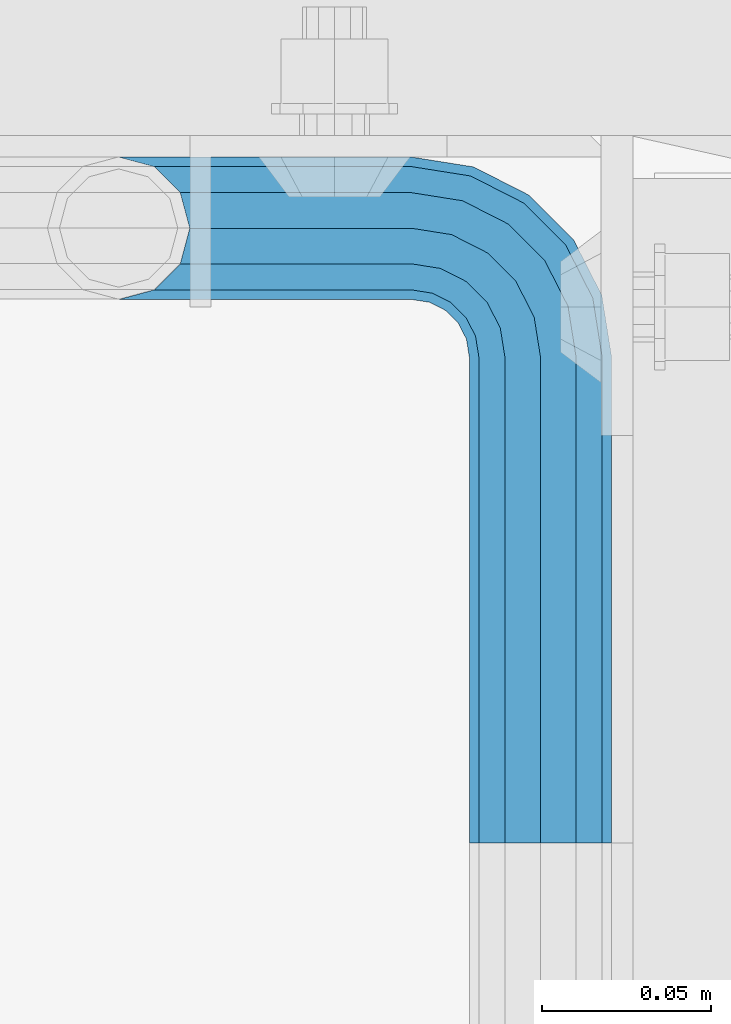
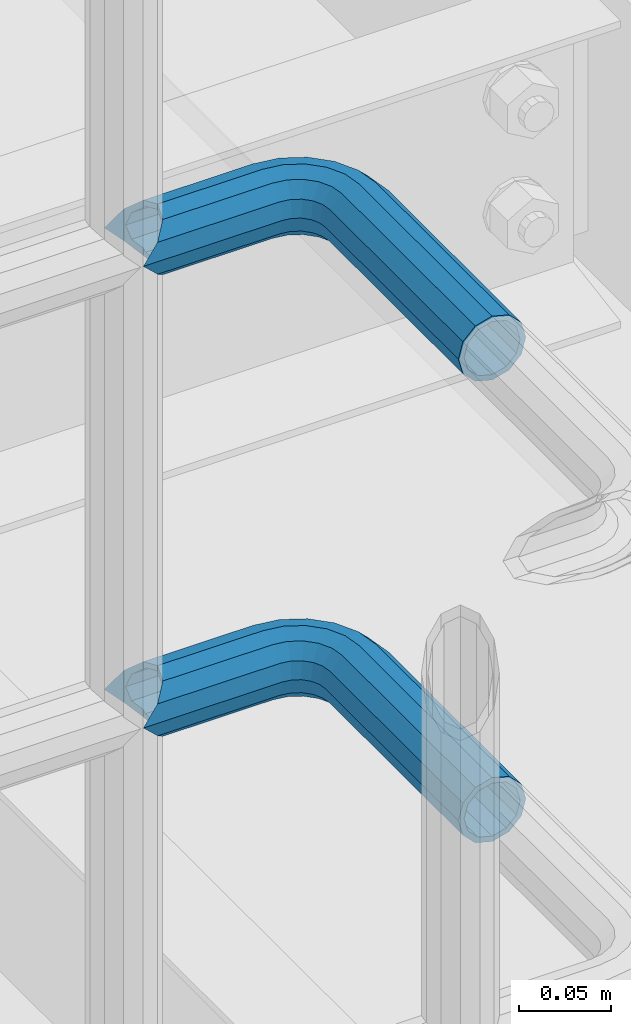
# One storey, part 1112 of 1876: 2 beams, 1 element without a shape of its own.
"""IFC2X3 building model written with IfcOpenShell, lengths in millimetres."""

import ifcopenshell
import ifcopenshell.guid

model = None  # the IFC model being written
_history = None  # IfcOwnerHistory: only IFC2X3 demands one
_inside = {}  # id of a spatial element -> (the spatial element, [elements in it])
_under = {}  # id of a project, library or spatial element -> (it, [spatial elements below it])
_declared = {}  # id of a project -> (the project, [libraries it declares])
_typed = {}  # id of a type object -> (the type object, [elements of that type])
_made_of = {}  # id of a material, layer set ... -> (it, [elements and type objects made of it])


def new_model(schema):
    """Start an empty IFC model of exactly this schema.

    Asked for "IFC4X3", IfcOpenShell would pick the latest addendum, in which some entities
    have other attributes; the version numbers below select the first issue.
    IFC2X3 requires an IfcOwnerHistory on every rooted entity: one is made here for all.
    """
    global model, _history
    if schema == "IFC4X3":
        model = ifcopenshell.file(schema_version=(4, 3, 0, 0))
    else:
        model = ifcopenshell.file(schema=schema)
    _inside.clear()
    _under.clear()
    _declared.clear()
    _typed.clear()
    _made_of.clear()
    _history = None
    if model.schema == "IFC2X3":
        org = make("IfcOrganization", Name="unknown")
        user = make(
            "IfcPersonAndOrganization",
            ThePerson=make("IfcPerson", FamilyName="unknown"),
            TheOrganization=org,
        )
        app = make(
            "IfcApplication",
            ApplicationDeveloper=org,
            Version="unknown",
            ApplicationFullName="unknown",
            ApplicationIdentifier="unknown",
        )
        _history = make(
            "IfcOwnerHistory",
            OwningUser=user,
            OwningApplication=app,
            ChangeAction="ADDED",
            CreationDate=0,
        )
    return model


def make(cls, **values):
    """One entity of the class cls with the attributes given. An attribute that is None is left unset."""
    return model.create_entity(
        cls, **{name: value for name, value in values.items() if value is not None}
    )


def rooted(cls, **values):
    """An entity with a GlobalId (a new one), such as an element, a storey or a relation."""
    return make(cls, GlobalId=ifcopenshell.guid.new(), OwnerHistory=_history, **values)


def si_unit(unit_type, name, prefix=None):
    """IfcSIUnit, for example si_unit("LENGTHUNIT", "METRE", prefix="MILLI")."""
    return make("IfcSIUnit", UnitType=unit_type, Prefix=prefix, Name=name)


def assignment(units):
    """IfcUnitAssignment: the units of a project."""
    return None if units is None else make("IfcUnitAssignment", Units=units)


def point(xyz):
    """IfcCartesianPoint."""
    return None if xyz is None else make("IfcCartesianPoint", Coordinates=xyz)


def direction(xyz):
    """IfcDirection."""
    return None if xyz is None else make("IfcDirection", DirectionRatios=xyz)


def frame(location, z_axis=None, x_axis=None):
    """IfcAxis2Placement3D, a coordinate frame: its origin and axes. An axis left out is left unset."""
    return make(
        "IfcAxis2Placement3D",
        Location=point(location),
        Axis=direction(z_axis),
        RefDirection=direction(x_axis),
    )


def origin_with_axes():
    """The frame at (0, 0, 0) with the z axis (0, 0, 1) and the x axis (1, 0, 0) written out."""
    return frame((0.0, 0.0, 0.0), z_axis=(0.0, 0.0, 1.0), x_axis=(1.0, 0.0, 0.0))


def place(relative_to, where):
    """IfcLocalPlacement: puts the frame where relative to a parent placement (None: the world)."""
    return make(
        "IfcLocalPlacement", PlacementRelTo=relative_to, RelativePlacement=where
    )


def context(
    kind, dimensions, precision=None, world=None, true_north=None, identifier=None
):
    """IfcGeometricRepresentationContext, for example the 3D "Model" context."""
    return make(
        "IfcGeometricRepresentationContext",
        ContextIdentifier=identifier,
        ContextType=kind,
        CoordinateSpaceDimension=dimensions,
        Precision=precision,
        WorldCoordinateSystem=world,
        TrueNorth=true_north,
    )


def subcontext(parent, identifier, kind, view, scale=None):
    """IfcGeometricRepresentationSubContext, for example "Body" below "Model"."""
    return make(
        "IfcGeometricRepresentationSubContext",
        ContextIdentifier=identifier,
        ContextType=kind,
        ParentContext=parent,
        TargetScale=scale,
        TargetView=view,
    )


def project(units=None, contexts=None):
    """IfcProject with its units and contexts."""
    return rooted(
        "IfcProject",
        Name="project",
        RepresentationContexts=contexts,
        UnitsInContext=assignment(units),
    )


def spatial(cls, under=None, at=None, **own):
    """A site, building, storey or space (cls), placed at a placement, below another one or the project."""
    s = rooted(cls, ObjectPlacement=at, **own)
    if under is not None:
        _under.setdefault(under.id(), (under, []))[1].append(s)
    return s


def faces_of(points, faces, orient=None, outer=None):
    """IfcFace entities. A face is a list of loops; a loop is a list of indices into points, from 0.

    orient and outer hold one flag for each loop. By default every Orientation is true, the
    first loop of a face is its IfcFaceOuterBound and the others are IfcFaceBound.
    """
    made = []
    for i, loops in enumerate(faces):
        bounds = []
        for j, loop in enumerate(loops):
            is_outer = j == 0 if outer is None else outer[i][j]
            bounds.append(
                make(
                    "IfcFaceOuterBound" if is_outer else "IfcFaceBound",
                    Bound=make("IfcPolyLoop", Polygon=[points[k] for k in loop]),
                    Orientation=True if orient is None else orient[i][j],
                )
            )
        made.append(make("IfcFace", Bounds=bounds))
    return made


def faceted_brep(points, faces, orient=None, outer=None, voids=None):
    """IfcFacetedBrep: a solid bounded by flat faces; with voids (closed shells), ...WithVoids."""
    shared = [point(p) for p in points]
    hull = make("IfcClosedShell", CfsFaces=faces_of(shared, faces, orient, outer))
    if voids is None:
        return make("IfcFacetedBrep", Outer=hull)
    return make(
        "IfcFacetedBrepWithVoids",
        Outer=hull,
        Voids=[
            make(cls, CfsFaces=faces_of(shared, fs, o, b)) for cls, fs, o, b in voids
        ],
    )


def shape(context_of_items, identifier, shape_type, items):
    """IfcShapeRepresentation: the items that make up one representation, for example the "Body"."""
    return make(
        "IfcShapeRepresentation",
        ContextOfItems=context_of_items,
        RepresentationIdentifier=identifier,
        RepresentationType=shape_type,
        Items=items,
    )


def material(Name=None, Category=None):
    """IfcMaterial."""
    return make("IfcMaterial", Name=Name, Category=Category)


def made_of(thing, what):
    """Note that an element or type object is made of a material, layer set ...; save() writes the relation."""
    if what is not None:
        _made_of.setdefault(what.id(), (what, []))[1].append(thing)
    return thing


def type_object(cls, material=None, **own):
    """A type object (cls), such as IfcWallType, which elements share."""
    return made_of(rooted(cls, **own), material)


def element(
    cls,
    number,
    at=None,
    inside=None,
    cuts=None,
    type_object=None,
    material=None,
    context=None,
    identifier="Body",
    shape_type=None,
    held_by="IfcProductDefinitionShape",
    body=None,
    shapes=None,
    **own,
):
    """One element of the class cls, such as IfcWall. Its Tag is "e" and its number.

    at: its placement. inside: the storey or other place that contains it. cuts: it is an
    opening in that element (IfcRelVoidsElement). A single representation is given by context,
    identifier, shape_type and body (its items); several are given by shapes. held_by: the class
    of the entity that holds the representations. save() writes the other relations.
    """
    e = rooted(cls, Tag="e%d" % number, ObjectPlacement=at, **own)
    if body is not None:
        shapes = [shape(context, identifier, shape_type, body)]
    if shapes is not None:
        e.Representation = make(held_by, Representations=shapes)
    if inside is not None:
        _inside.setdefault(inside.id(), (inside, []))[1].append(e)
    if cuts is not None:
        rooted(
            "IfcRelVoidsElement", RelatingBuildingElement=cuts, RelatedOpeningElement=e
        )
    if type_object is not None:
        _typed.setdefault(type_object.id(), (type_object, []))[1].append(e)
    return made_of(e, material)


def aggregate(whole, parts):
    """IfcRelAggregates: a whole, such as a stair, and the parts it consists of."""
    return rooted("IfcRelAggregates", RelatingObject=whole, RelatedObjects=parts)


def save(model, path):
    """Write the relations noted so far, then the file.

    IfcRelAggregates (storeys below a building ...), IfcRelContainedInSpatialStructure (elements
    in a storey), IfcRelDefinesByType, IfcRelAssociatesMaterial and IfcRelDeclares: one each for
    every whole, place, type object, material and project.
    """
    for whole, parts in _under.values():
        aggregate(whole, parts)
    for where, things in _inside.values():
        rooted(
            "IfcRelContainedInSpatialStructure",
            RelatedElements=things,
            RelatingStructure=where,
        )
    for kind, things in _typed.values():
        rooted("IfcRelDefinesByType", RelatedObjects=things, RelatingType=kind)
    for what, things in _made_of.values():
        rooted("IfcRelAssociatesMaterial", RelatedObjects=things, RelatingMaterial=what)
    for by, libraries in _declared.values():
        rooted("IfcRelDeclares", RelatingContext=by, RelatedDefinitions=libraries)
    model.write(path)


model = new_model("IFC2X3")

# Units and contexts
model_context = context("Model", 3, precision=1e-05, world=origin_with_axes())
body_context = subcontext(model_context, "Body", "Model", "MODEL_VIEW")
ifc_project = project(units=[si_unit("LENGTHUNIT", "METRE", prefix="MILLI"), si_unit("AREAUNIT", "SQUARE_METRE"), si_unit("VOLUMEUNIT", "CUBIC_METRE"), si_unit("MASSUNIT", "GRAM", prefix="KILO"), si_unit("TIMEUNIT", "SECOND"), si_unit("PLANEANGLEUNIT", "RADIAN"), si_unit("SOLIDANGLEUNIT", "STERADIAN"), si_unit("THERMODYNAMICTEMPERATUREUNIT", "DEGREE_CELSIUS"), si_unit("LUMINOUSINTENSITYUNIT", "LUMEN")], contexts=[model_context])

# Site, building, storey
site_placement = place(None, origin_with_axes())
site = spatial("IfcSite", under=ifc_project, at=site_placement, CompositionType="ELEMENT")
building_placement = place(site_placement, origin_with_axes())
building = spatial("IfcBuilding", under=site, at=building_placement, Name="Undefined", CompositionType="ELEMENT")
storey_placement = place(building_placement, origin_with_axes())
storey = spatial("IfcBuildingStorey", under=building, at=storey_placement, Name="Undefined", CompositionType="ELEMENT", Elevation=0.0)

# Assembly, beams
assembly_placement = place(storey_placement, origin_with_axes())
assembly = element("IfcElementAssembly", 1, at=assembly_placement, inside=storey, Name="HANDRAIL", AssemblyPlace="NOTDEFINED", PredefinedType="RIGID_FRAME")
ifc_material = material()
beam_type = type_object("IfcBeamType", Name="PIPE1-1/4STD", PredefinedType="NOTDEFINED")
beam_1_placement = place(assembly_placement, frame((4696.96656849878, -11563.3144042962, 8480.425), z_axis=(0.0, 0.0, -1.0), x_axis=(0.0, 1.0, 0.0)))
beam_1 = element("IfcBeam", 2, at=beam_1_placement, type_object=beam_type, material=ifc_material, Name="HANDRAIL", ObjectType="PIPE1-1/4STD", context=body_context, shape_type="Brep", body=[
    faceted_brep([(160.964844482422, -124.968002319336, 0.0), (163.789296919838, -114.42699926758, -10.5409999999993), (163.789296919838, -114.42699926758, 10.5409999999993), (190.809844482423, -106.234034770496, -15.1779612267255), (182.046844482422, -103.88599926758, -17.5259999999998), (182.046844482422, -103.88599926758, -21.0820000000003), (192.587844482423, -106.710451704997, -18.2575475625836), (192.587856687565, -106.710451704997, -13.3999490215811), (173.283844482423, -106.234041311212, -15.1779612267255), (171.505856687567, -106.710451704997, -13.3999734318695), (171.505844482423, -106.710451704997, -18.2575475625836), (166.868883255696, -111.347425136867, -8.76300000000083), (164.520844482422, -113.69546391014, 0.0), (166.868883255696, -111.347425136867, 8.76300000000083), (171.505856687567, -106.710451704997, 13.3999734318695), (171.505844482423, -106.710451704997, 18.2575475625836), (173.283844482423, -106.234041311212, 15.1779612267255), (182.046844482422, -103.88599926758, 17.5259999999998), (182.046844482422, -103.88599926758, 21.0820000000003), (190.809844482423, -106.234034770496, 15.1779612267255), (192.587856687565, -106.710451704997, 13.3999490215811), (192.587844482423, -106.710451704997, 18.2575475625836), (203.128856687566, -124.96799926758, 0.0), (200.304392045005, -114.42699926758, 10.5409999999993), (200.304392045005, -114.42699926758, -10.5409999999993), (197.224805709147, -111.347400726579, 8.76300000000083), (199.572844482422, -113.695439499853, 0.0), (197.224805709147, -111.347400726579, -8.76300000000083), (0.0, -18.2575475625836, -10.5409999999993), (0.0, -10.5410000000002, -18.2575475625836), (143.946846008301, -10.5410000000011, -18.2575475625836), (143.946846008301, -18.2575475625854, -10.5409999999993), (-4.28826751885936e-09, 0.0, -21.0820000000003), (143.946846008301, -1.81898940354586e-12, -21.0820000000003), (0.0, 10.5410000000002, -18.2575475625836), (143.946846008301, 10.5409999999983, -18.2575475625836), (0.0, 18.2575475625836, -10.5409999999993), (143.946846008301, 18.2575475625817, -10.5409999999993), (9.09494701772928e-13, 21.0820000000003, 0.0), (143.946846008301, 21.0819999999985, 0.0), (0.0, 18.2575475625836, 10.5409999999993), (143.946846008301, 18.2575475625817, 10.5409999999993), (0.0, 10.5410000000002, 18.2575475625836), (143.946846008301, 10.5409999999983, 18.2575475625836), (0.0, 0.0, 21.0820000000003), (143.946846008301, -1.81898940354586e-12, 21.0820000000003), (0.0, -10.5410000000002, 18.2575475625836), (143.946846008301, -10.5410000000011, 18.2575475625836), (0.0, -18.2575475625836, 10.5409999999993), (143.946846008301, -18.2575475625854, 10.5409999999993), (9.09494701772928e-13, -21.0820000000003, 0.0), (143.946846008301, -21.0820000000012, 0.0), (149.205696747053, -21.9149201310092, 0.0), (150.078500550018, -19.2287062354389, 10.5409999999993), (152.46304488476, -11.8898333927427, 18.2575475625836), (155.720393022468, -1.86474665447531, 21.0820000000003), (158.977741160175, 8.1603400837912, 18.2575475625836), (161.362285494917, 15.4992129264883, 10.5409999999993), (162.235089297883, 18.1854268220586, 0.0), (161.362285494917, 15.4992129264883, -10.5409999999993), (158.977741160175, 8.1603400837912, -18.2575475625836), (155.720393022468, -1.86474665447531, -21.0820000000003), (152.46304488476, -11.8898333927427, -18.2575475625836), (150.078500550018, -19.2287062354389, -10.5409999999993), (200.304392045007, -38.099998474122, -10.5409999999993), (203.128844482424, -38.099998474122, 0.0), (182.046844482424, -38.099998474122, -21.0820000000003), (192.587844482425, -38.099998474122, -18.2575475625836), (171.505844482424, -38.0999984741229, -18.2575475625836), (163.78929691984, -38.0999984741229, -10.5409999999993), (160.964844482422, -38.0999984741229, 0.0), (163.78929691984, -38.0999984741229, 10.5409999999993), (171.505844482424, -38.0999984741229, 18.2575475625836), (182.046844482424, -38.099998474122, 21.0820000000003), (192.587844482425, -38.099998474122, 18.2575475625836), (200.304392045007, -38.099998474122, 10.5409999999993), (197.546057408912, -20.6845589875047, -10.5409999999993), (190.207184566216, -23.0691033222465, -18.2575475625836), (200.232271304483, -19.8117551845389, 0.0), (197.546057408912, -20.6845589875047, 10.5409999999993), (190.207184566216, -23.0691033222465, 18.2575475625836), (180.182097827948, -26.3264514599541, 21.0820000000003), (170.157011089683, -29.5837995976626, 18.2575475625836), (162.818138246987, -31.9683439324044, 10.5409999999993), (160.131924351415, -32.8411477353702, 0.0), (162.818138246987, -31.9683439324044, -10.5409999999993), (170.157011089683, -29.5837995976626, -18.2575475625836), (180.182097827948, -26.3264514599541, -21.0820000000003), (183.298240397229, -9.50953691424911, -18.2575475625836), (174.770392259523, -15.7053812586646, -21.0820000000003), (189.541058513261, -4.97386405834823, -10.5409999999993), (191.826088534934, -3.31369256983271, 0.0), (189.541058513261, -4.97386405834823, 10.5409999999993), (183.298240397229, -9.50953691424911, 18.2575475625836), (174.770392259523, -15.7053812586646, 21.0820000000003), (166.242544121817, -21.901225603081, 18.2575475625836), (159.999726005784, -26.4368984589819, 10.5409999999993), (157.714695984112, -28.0970699474974, 0.0), (159.999726005784, -26.4368984589819, -10.5409999999993), (166.242544121817, -21.901225603081, -18.2575475625836), (166.341463223758, -7.27645222290084, -21.0820000000003), (160.145618879342, -15.8043003606062, -18.2575475625836), (172.537307568173, 1.25139591480547, -18.2575475625836), (177.072980424075, 7.49421403083761, -10.5409999999993), (178.733151912589, 9.77924405251179, 0.0), (177.072980424075, 7.49421403083761, 10.5409999999993), (172.537307568173, 1.25139591480547, 18.2575475625836), (166.341463223758, -7.27645222290084, 21.0820000000003), (160.145618879342, -15.8043003606062, 18.2575475625836), (155.609946023442, -22.0471184766393, 10.5409999999993), (153.949774534927, -24.3321484983126, 0.0), (155.609946023442, -22.0471184766393, -10.5409999999993), (0.0, -15.1779612267264, -8.76300000000083), (0.0, -8.76299999999992, -15.1779612267255), (0.0, 0.0, -17.5259999999998), (0.0, 8.76299999999992, -15.1779612267255), (0.0, 15.1779612267264, -8.76300000000083), (0.0, 17.5259999999998, 0.0), (0.0, 15.1779612267264, 8.76300000000083), (0.0, 8.76299999999992, 15.1779612267255), (0.0, 0.0, 17.5259999999998), (0.0, -8.76299999999992, 15.1779612267255), (0.0, -15.1779612267264, 8.76300000000083), (0.0, -17.5259999999998, 0.0), (143.946846008301, 8.76299999999901, -15.1779612267255), (143.946846008301, 15.1779612267246, -8.76300000000083), (143.946846008301, 17.5259999999989, 0.0), (143.946846008301, 15.1779612267246, 8.76300000000083), (143.946846008301, 8.76299999999901, 15.1779612267255), (143.946846008301, -1.81898940354586e-12, 17.5259999999998), (143.946846008301, -8.76300000000174, 15.1779612267255), (143.946846008301, -15.1779612267273, 8.76300000000083), (143.946846008301, -17.5260000000017, 0.0), (143.946846008301, -15.1779612267273, -8.76300000000083), (143.946846008301, -8.76300000000174, -15.1779612267255), (143.946846008301, -1.81898940354586e-12, -17.5259999999998), (155.720393022468, -1.86474665447531, -17.5259999999998), (158.428308944176, 6.46936159781853, -15.1779612267255), (160.410640981492, 12.570352274277, -8.76300000000083), (161.136224865884, 14.8034698501133, 0.0), (160.410640981492, 12.570352274277, 8.76300000000083), (158.428308944176, 6.46936159781853, 15.1779612267255), (155.720393022468, -1.86474665447531, 17.5259999999998), (153.012477100759, -10.1988549067692, 15.1779612267255), (151.030145063443, -16.2998455832276, 8.76300000000083), (150.304561179051, -18.5329631590639, 0.0), (151.030145063443, -16.2998455832276, -8.76300000000083), (153.012477100759, -10.1988549067692, -15.1779612267255), (161.190701057918, -14.3658681446077, -15.1779612267255), (166.341463223758, -7.27645222290084, -17.5259999999998), (157.42008145482, -19.5556807952853, -8.76300000000083), (156.03993889208, -21.4552840663155, 0.0), (157.42008145482, -19.5556807952853, 8.76300000000083), (161.190701057918, -14.3658681446077, 15.1779612267255), (166.341463223758, -7.27645222290084, 17.5259999999998), (171.492225389597, -0.187036301193075, 15.1779612267255), (175.262844992696, 5.00277634948452, 8.76300000000083), (176.642987555437, 6.90237962051378, 0.0), (175.262844992696, 5.00277634948452, -8.76300000000083), (171.492225389597, -0.187036301193075, -15.1779612267255), (174.770392259523, -15.7053812586646, -17.5259999999998), (181.859808181231, -10.5546190928253, -15.1779612267255), (167.680976337815, -20.8561434245048, -15.1779612267255), (162.491163687138, -24.6267630276034, -8.76300000000083), (160.591560416109, -26.006905590345, 0.0), (162.491163687138, -24.6267630276034, 8.76300000000083), (167.680976337815, -20.8561434245048, 15.1779612267255), (174.770392259523, -15.7053812586646, 17.5259999999998), (181.859808181231, -10.5546190928253, 15.1779612267255), (187.049620831907, -6.78399948972674, 8.76300000000083), (188.949224102937, -5.4038569269851, 0.0), (187.049620831907, -6.78399948972674, -8.76300000000083), (188.516206080243, -23.6185355382449, -15.1779612267255), (194.617196756701, -21.6362035009297, -8.76300000000083), (180.182097827948, -26.3264514599541, -17.5259999999998), (171.847989575655, -29.0343673816633, -15.1779612267255), (165.746998899196, -31.0166994189794, -8.76300000000083), (163.513881323361, -31.7422833033725, 0.0), (165.746998899196, -31.0166994189794, 8.76300000000083), (171.847989575655, -29.0343673816633, 15.1779612267255), (180.182097827948, -26.3264514599541, 17.5259999999998), (188.516206080243, -23.6185355382449, 15.1779612267255), (194.617196756701, -21.6362035009297, 8.76300000000083), (196.850314332538, -20.9106196165367, 0.0), (197.224805709149, -38.099998474122, -8.76300000000083), (199.572844482424, -38.099998474122, 0.0), (190.809844482425, -38.099998474122, -15.1779612267255), (182.046844482424, -38.099998474122, -17.5259999999998), (173.283844482423, -38.099998474122, -15.1779612267255), (166.868883255698, -38.0999984741229, -8.76300000000083), (164.520844482422, -38.0999984741229, 0.0), (166.868883255698, -38.0999984741229, 8.76300000000083), (173.283844482423, -38.099998474122, 15.1779612267255), (182.046844482424, -38.099998474122, 17.5259999999998), (190.809844482425, -38.099998474122, 15.1779612267255), (197.224805709149, -38.099998474122, 8.76300000000083)], [[[0, 1, 2]], [[3, 4, 5, 6, 7]], [[8, 9, 10, 5, 4]], [[2, 1, 10, 9, 11, 12, 13, 14, 15]], [[15, 14, 16, 17, 18]], [[18, 17, 19, 20, 21]], [[22, 23, 24]], [[21, 20, 25, 26, 27, 7, 6, 24, 23]], [[28, 29, 30, 31]], [[29, 32, 33, 30]], [[32, 34, 35, 33]], [[34, 36, 37, 35]], [[36, 38, 39, 37]], [[38, 40, 41, 39]], [[40, 42, 43, 41]], [[42, 44, 45, 43]], [[44, 46, 47, 45]], [[46, 48, 49, 47]], [[48, 50, 51, 49]], [[49, 51, 52, 53]], [[47, 49, 53, 54]], [[45, 47, 54, 55]], [[43, 45, 55, 56]], [[41, 43, 56, 57]], [[39, 41, 57, 58]], [[37, 39, 58, 59]], [[35, 37, 59, 60]], [[33, 35, 60, 61]], [[30, 33, 61, 62]], [[31, 30, 62, 63]], [[64, 65, 22, 24]], [[66, 67, 6, 5]], [[68, 66, 5, 10]], [[69, 68, 10, 1]], [[70, 69, 1, 0]], [[71, 70, 0, 2]], [[72, 71, 2, 15]], [[73, 72, 15, 18]], [[74, 73, 18, 21]], [[75, 74, 21, 23]], [[65, 75, 23, 22]], [[67, 64, 24, 6]], [[76, 64, 67, 77]], [[78, 65, 64, 76]], [[79, 75, 65, 78]], [[80, 74, 75, 79]], [[81, 73, 74, 80]], [[82, 72, 73, 81]], [[83, 71, 72, 82]], [[84, 70, 71, 83]], [[85, 69, 70, 84]], [[86, 68, 69, 85]], [[87, 66, 68, 86]], [[77, 67, 66, 87]], [[88, 77, 87, 89]], [[90, 76, 77, 88]], [[91, 78, 76, 90]], [[92, 79, 78, 91]], [[93, 80, 79, 92]], [[94, 81, 80, 93]], [[95, 82, 81, 94]], [[96, 83, 82, 95]], [[97, 84, 83, 96]], [[98, 85, 84, 97]], [[99, 86, 85, 98]], [[89, 87, 86, 99]], [[100, 89, 99, 101]], [[102, 88, 89, 100]], [[103, 90, 88, 102]], [[104, 91, 90, 103]], [[105, 92, 91, 104]], [[106, 93, 92, 105]], [[107, 94, 93, 106]], [[108, 95, 94, 107]], [[109, 96, 95, 108]], [[110, 97, 96, 109]], [[111, 98, 97, 110]], [[101, 99, 98, 111]], [[62, 101, 111, 63]], [[61, 100, 101, 62]], [[60, 102, 100, 61]], [[59, 103, 102, 60]], [[58, 104, 103, 59]], [[57, 105, 104, 58]], [[56, 106, 105, 57]], [[55, 107, 106, 56]], [[54, 108, 107, 55]], [[53, 109, 108, 54]], [[52, 110, 109, 53]], [[63, 111, 110, 52]], [[51, 31, 63, 52]], [[50, 28, 31, 51]], [[48, 46, 44, 42, 40, 38, 36, 34, 32, 29, 28, 50], [112, 113, 114, 115, 116, 117, 118, 119, 120, 121, 122, 123]], [[116, 115, 124, 125]], [[117, 116, 125, 126]], [[118, 117, 126, 127]], [[119, 118, 127, 128]], [[120, 119, 128, 129]], [[121, 120, 129, 130]], [[122, 121, 130, 131]], [[123, 122, 131, 132]], [[112, 123, 132, 133]], [[113, 112, 133, 134]], [[114, 113, 134, 135]], [[115, 114, 135, 124]], [[124, 135, 136, 137]], [[125, 124, 137, 138]], [[126, 125, 138, 139]], [[127, 126, 139, 140]], [[128, 127, 140, 141]], [[129, 128, 141, 142]], [[130, 129, 142, 143]], [[131, 130, 143, 144]], [[132, 131, 144, 145]], [[133, 132, 145, 146]], [[134, 133, 146, 147]], [[135, 134, 147, 136]], [[147, 148, 149, 136]], [[146, 150, 148, 147]], [[145, 151, 150, 146]], [[144, 152, 151, 145]], [[143, 153, 152, 144]], [[142, 154, 153, 143]], [[141, 155, 154, 142]], [[140, 156, 155, 141]], [[139, 157, 156, 140]], [[138, 158, 157, 139]], [[137, 159, 158, 138]], [[136, 149, 159, 137]], [[149, 160, 161, 159]], [[148, 162, 160, 149]], [[150, 163, 162, 148]], [[151, 164, 163, 150]], [[152, 165, 164, 151]], [[153, 166, 165, 152]], [[154, 167, 166, 153]], [[155, 168, 167, 154]], [[156, 169, 168, 155]], [[157, 170, 169, 156]], [[158, 171, 170, 157]], [[159, 161, 171, 158]], [[161, 172, 173, 171]], [[160, 174, 172, 161]], [[162, 175, 174, 160]], [[163, 176, 175, 162]], [[164, 177, 176, 163]], [[165, 178, 177, 164]], [[166, 179, 178, 165]], [[167, 180, 179, 166]], [[168, 181, 180, 167]], [[169, 182, 181, 168]], [[170, 183, 182, 169]], [[171, 173, 183, 170]], [[173, 184, 185, 183]], [[172, 186, 184, 173]], [[174, 187, 186, 172]], [[175, 188, 187, 174]], [[176, 189, 188, 175]], [[177, 190, 189, 176]], [[178, 191, 190, 177]], [[179, 192, 191, 178]], [[180, 193, 192, 179]], [[181, 194, 193, 180]], [[182, 195, 194, 181]], [[183, 185, 195, 182]], [[195, 185, 26, 25]], [[19, 194, 195, 25, 20]], [[193, 194, 19, 17]], [[192, 193, 17, 16]], [[13, 191, 192, 16, 14]], [[190, 191, 13, 12]], [[189, 190, 12, 11]], [[188, 189, 11, 9, 8]], [[187, 188, 8, 4]], [[186, 187, 4, 3]], [[184, 186, 3, 7, 27]], [[185, 184, 27, 26]]]),
])
beam_2_placement = place(assembly_placement, frame((4696.96656849878, -11563.3144042962, 8785.225), z_axis=(0.0, 0.0, -1.0), x_axis=(0.0, 1.0, 0.0)))
beam_2 = element("IfcBeam", 3, at=beam_2_placement, type_object=beam_type, material=ifc_material, Name="HANDRAIL", ObjectType="PIPE1-1/4STD", context=body_context, shape_type="Brep", body=[
    faceted_brep([(160.964844482422, -124.968002319336, 0.0), (163.789296919838, -114.42699926758, -10.5409999999993), (163.789296919838, -114.42699926758, 10.5409999999993), (190.809844482423, -106.234034770496, -15.1779612267255), (182.046844482422, -103.88599926758, -17.5259999999998), (182.046844482422, -103.88599926758, -21.0820000000003), (192.587844482423, -106.710451704997, -18.2575475625836), (192.587856687565, -106.710451704997, -13.3999490215811), (173.283844482423, -106.234041311212, -15.1779612267255), (171.505856687567, -106.710451704997, -13.3999734318695), (171.505844482423, -106.710451704997, -18.2575475625836), (166.868883255696, -111.347425136867, -8.76300000000083), (164.520844482422, -113.69546391014, 0.0), (166.868883255696, -111.347425136867, 8.76300000000083), (171.505856687567, -106.710451704997, 13.3999734318695), (171.505844482423, -106.710451704997, 18.2575475625836), (173.283844482423, -106.234041311212, 15.1779612267255), (182.046844482422, -103.88599926758, 17.5259999999998), (182.046844482422, -103.88599926758, 21.0820000000003), (190.809844482423, -106.234034770496, 15.1779612267255), (192.587856687565, -106.710451704997, 13.3999490215811), (192.587844482423, -106.710451704997, 18.2575475625836), (203.128856687566, -124.96799926758, 0.0), (200.304392045005, -114.42699926758, 10.5409999999993), (200.304392045005, -114.42699926758, -10.5409999999993), (197.224805709147, -111.347400726579, 8.76300000000083), (199.572844482422, -113.695439499853, 0.0), (197.224805709147, -111.347400726579, -8.76300000000083), (0.0, -18.2575475625836, -10.5409999999993), (0.0, -10.5410000000002, -18.2575475625836), (143.946846008301, -10.5410000000011, -18.2575475625836), (143.946846008301, -18.2575475625854, -10.5409999999993), (-4.28826751885936e-09, 0.0, -21.0820000000003), (143.946846008301, -1.81898940354586e-12, -21.0820000000003), (0.0, 10.5410000000002, -18.2575475625836), (143.946846008301, 10.5409999999983, -18.2575475625836), (0.0, 18.2575475625836, -10.5409999999993), (143.946846008301, 18.2575475625817, -10.5409999999993), (9.09494701772928e-13, 21.0820000000003, 0.0), (143.946846008301, 21.0819999999985, 0.0), (0.0, 18.2575475625836, 10.5409999999993), (143.946846008301, 18.2575475625817, 10.5409999999993), (0.0, 10.5410000000002, 18.2575475625836), (143.946846008301, 10.5409999999983, 18.2575475625836), (0.0, 0.0, 21.0820000000003), (143.946846008301, -1.81898940354586e-12, 21.0820000000003), (0.0, -10.5410000000002, 18.2575475625836), (143.946846008301, -10.5410000000011, 18.2575475625836), (0.0, -18.2575475625836, 10.5409999999993), (143.946846008301, -18.2575475625854, 10.5409999999993), (9.09494701772928e-13, -21.0820000000003, 0.0), (143.946846008301, -21.0820000000012, 0.0), (149.205696747053, -21.9149201310092, 0.0), (150.078500550018, -19.2287062354389, 10.5409999999993), (152.46304488476, -11.8898333927427, 18.2575475625836), (155.720393022468, -1.86474665447531, 21.0820000000003), (158.977741160175, 8.1603400837912, 18.2575475625836), (161.362285494917, 15.4992129264883, 10.5409999999993), (162.235089297883, 18.1854268220586, 0.0), (161.362285494917, 15.4992129264883, -10.5409999999993), (158.977741160175, 8.1603400837912, -18.2575475625836), (155.720393022468, -1.86474665447531, -21.0820000000003), (152.46304488476, -11.8898333927427, -18.2575475625836), (150.078500550018, -19.2287062354389, -10.5409999999993), (200.304392045007, -38.099998474122, -10.5409999999993), (203.128844482424, -38.099998474122, 0.0), (182.046844482424, -38.099998474122, -21.0820000000003), (192.587844482425, -38.099998474122, -18.2575475625836), (171.505844482424, -38.0999984741229, -18.2575475625836), (163.78929691984, -38.0999984741229, -10.5409999999993), (160.964844482422, -38.0999984741229, 0.0), (163.78929691984, -38.0999984741229, 10.5409999999993), (171.505844482424, -38.0999984741229, 18.2575475625836), (182.046844482424, -38.099998474122, 21.0820000000003), (192.587844482425, -38.099998474122, 18.2575475625836), (200.304392045007, -38.099998474122, 10.5409999999993), (197.546057408912, -20.6845589875047, -10.5409999999993), (190.207184566216, -23.0691033222465, -18.2575475625836), (200.232271304483, -19.8117551845389, 0.0), (197.546057408912, -20.6845589875047, 10.5409999999993), (190.207184566216, -23.0691033222465, 18.2575475625836), (180.182097827948, -26.3264514599541, 21.0820000000003), (170.157011089683, -29.5837995976626, 18.2575475625836), (162.818138246987, -31.9683439324044, 10.5409999999993), (160.131924351415, -32.8411477353702, 0.0), (162.818138246987, -31.9683439324044, -10.5409999999993), (170.157011089683, -29.5837995976626, -18.2575475625836), (180.182097827948, -26.3264514599541, -21.0820000000003), (183.298240397229, -9.50953691424911, -18.2575475625836), (174.770392259523, -15.7053812586646, -21.0820000000003), (189.541058513261, -4.97386405834823, -10.5409999999993), (191.826088534934, -3.31369256983271, 0.0), (189.541058513261, -4.97386405834823, 10.5409999999993), (183.298240397229, -9.50953691424911, 18.2575475625836), (174.770392259523, -15.7053812586646, 21.0820000000003), (166.242544121817, -21.901225603081, 18.2575475625836), (159.999726005784, -26.4368984589819, 10.5409999999993), (157.714695984112, -28.0970699474974, 0.0), (159.999726005784, -26.4368984589819, -10.5409999999993), (166.242544121817, -21.901225603081, -18.2575475625836), (166.341463223758, -7.27645222290084, -21.0820000000003), (160.145618879342, -15.8043003606062, -18.2575475625836), (172.537307568173, 1.25139591480547, -18.2575475625836), (177.072980424075, 7.49421403083761, -10.5409999999993), (178.733151912589, 9.77924405251179, 0.0), (177.072980424075, 7.49421403083761, 10.5409999999993), (172.537307568173, 1.25139591480547, 18.2575475625836), (166.341463223758, -7.27645222290084, 21.0820000000003), (160.145618879342, -15.8043003606062, 18.2575475625836), (155.609946023442, -22.0471184766393, 10.5409999999993), (153.949774534927, -24.3321484983126, 0.0), (155.609946023442, -22.0471184766393, -10.5409999999993), (0.0, -15.1779612267264, -8.76300000000083), (0.0, -8.76299999999992, -15.1779612267255), (0.0, 0.0, -17.5259999999998), (0.0, 8.76299999999992, -15.1779612267255), (0.0, 15.1779612267264, -8.76300000000083), (0.0, 17.5259999999998, 0.0), (0.0, 15.1779612267264, 8.76300000000083), (0.0, 8.76299999999992, 15.1779612267255), (0.0, 0.0, 17.5259999999998), (0.0, -8.76299999999992, 15.1779612267255), (0.0, -15.1779612267264, 8.76300000000083), (0.0, -17.5259999999998, 0.0), (143.946846008301, 8.76299999999901, -15.1779612267255), (143.946846008301, 15.1779612267246, -8.76300000000083), (143.946846008301, 17.5259999999989, 0.0), (143.946846008301, 15.1779612267246, 8.76300000000083), (143.946846008301, 8.76299999999901, 15.1779612267255), (143.946846008301, -1.81898940354586e-12, 17.5259999999998), (143.946846008301, -8.76300000000174, 15.1779612267255), (143.946846008301, -15.1779612267273, 8.76300000000083), (143.946846008301, -17.5260000000017, 0.0), (143.946846008301, -15.1779612267273, -8.76300000000083), (143.946846008301, -8.76300000000174, -15.1779612267255), (143.946846008301, -1.81898940354586e-12, -17.5259999999998), (155.720393022468, -1.86474665447531, -17.5259999999998), (158.428308944176, 6.46936159781853, -15.1779612267255), (160.410640981492, 12.570352274277, -8.76300000000083), (161.136224865884, 14.8034698501133, 0.0), (160.410640981492, 12.570352274277, 8.76300000000083), (158.428308944176, 6.46936159781853, 15.1779612267255), (155.720393022468, -1.86474665447531, 17.5259999999998), (153.012477100759, -10.1988549067692, 15.1779612267255), (151.030145063443, -16.2998455832276, 8.76300000000083), (150.304561179051, -18.5329631590639, 0.0), (151.030145063443, -16.2998455832276, -8.76300000000083), (153.012477100759, -10.1988549067692, -15.1779612267255), (161.190701057918, -14.3658681446077, -15.1779612267255), (166.341463223758, -7.27645222290084, -17.5259999999998), (157.42008145482, -19.5556807952853, -8.76300000000083), (156.03993889208, -21.4552840663155, 0.0), (157.42008145482, -19.5556807952853, 8.76300000000083), (161.190701057918, -14.3658681446077, 15.1779612267255), (166.341463223758, -7.27645222290084, 17.5259999999998), (171.492225389597, -0.187036301193075, 15.1779612267255), (175.262844992696, 5.00277634948452, 8.76300000000083), (176.642987555437, 6.90237962051378, 0.0), (175.262844992696, 5.00277634948452, -8.76300000000083), (171.492225389597, -0.187036301193075, -15.1779612267255), (174.770392259523, -15.7053812586646, -17.5259999999998), (181.859808181231, -10.5546190928253, -15.1779612267255), (167.680976337815, -20.8561434245048, -15.1779612267255), (162.491163687138, -24.6267630276034, -8.76300000000083), (160.591560416109, -26.006905590345, 0.0), (162.491163687138, -24.6267630276034, 8.76300000000083), (167.680976337815, -20.8561434245048, 15.1779612267255), (174.770392259523, -15.7053812586646, 17.5259999999998), (181.859808181231, -10.5546190928253, 15.1779612267255), (187.049620831907, -6.78399948972674, 8.76300000000083), (188.949224102937, -5.4038569269851, 0.0), (187.049620831907, -6.78399948972674, -8.76300000000083), (188.516206080243, -23.6185355382449, -15.1779612267255), (194.617196756701, -21.6362035009297, -8.76300000000083), (180.182097827948, -26.3264514599541, -17.5259999999998), (171.847989575655, -29.0343673816633, -15.1779612267255), (165.746998899196, -31.0166994189794, -8.76300000000083), (163.513881323361, -31.7422833033725, 0.0), (165.746998899196, -31.0166994189794, 8.76300000000083), (171.847989575655, -29.0343673816633, 15.1779612267255), (180.182097827948, -26.3264514599541, 17.5259999999998), (188.516206080243, -23.6185355382449, 15.1779612267255), (194.617196756701, -21.6362035009297, 8.76300000000083), (196.850314332538, -20.9106196165367, 0.0), (197.224805709149, -38.099998474122, -8.76300000000083), (199.572844482424, -38.099998474122, 0.0), (190.809844482425, -38.099998474122, -15.1779612267255), (182.046844482424, -38.099998474122, -17.5259999999998), (173.283844482423, -38.099998474122, -15.1779612267255), (166.868883255698, -38.0999984741229, -8.76300000000083), (164.520844482422, -38.0999984741229, 0.0), (166.868883255698, -38.0999984741229, 8.76300000000083), (173.283844482423, -38.099998474122, 15.1779612267255), (182.046844482424, -38.099998474122, 17.5259999999998), (190.809844482425, -38.099998474122, 15.1779612267255), (197.224805709149, -38.099998474122, 8.76300000000083)], [[[0, 1, 2]], [[3, 4, 5, 6, 7]], [[8, 9, 10, 5, 4]], [[2, 1, 10, 9, 11, 12, 13, 14, 15]], [[15, 14, 16, 17, 18]], [[18, 17, 19, 20, 21]], [[22, 23, 24]], [[21, 20, 25, 26, 27, 7, 6, 24, 23]], [[28, 29, 30, 31]], [[29, 32, 33, 30]], [[32, 34, 35, 33]], [[34, 36, 37, 35]], [[36, 38, 39, 37]], [[38, 40, 41, 39]], [[40, 42, 43, 41]], [[42, 44, 45, 43]], [[44, 46, 47, 45]], [[46, 48, 49, 47]], [[48, 50, 51, 49]], [[49, 51, 52, 53]], [[47, 49, 53, 54]], [[45, 47, 54, 55]], [[43, 45, 55, 56]], [[41, 43, 56, 57]], [[39, 41, 57, 58]], [[37, 39, 58, 59]], [[35, 37, 59, 60]], [[33, 35, 60, 61]], [[30, 33, 61, 62]], [[31, 30, 62, 63]], [[64, 65, 22, 24]], [[66, 67, 6, 5]], [[68, 66, 5, 10]], [[69, 68, 10, 1]], [[70, 69, 1, 0]], [[71, 70, 0, 2]], [[72, 71, 2, 15]], [[73, 72, 15, 18]], [[74, 73, 18, 21]], [[75, 74, 21, 23]], [[65, 75, 23, 22]], [[67, 64, 24, 6]], [[76, 64, 67, 77]], [[78, 65, 64, 76]], [[79, 75, 65, 78]], [[80, 74, 75, 79]], [[81, 73, 74, 80]], [[82, 72, 73, 81]], [[83, 71, 72, 82]], [[84, 70, 71, 83]], [[85, 69, 70, 84]], [[86, 68, 69, 85]], [[87, 66, 68, 86]], [[77, 67, 66, 87]], [[88, 77, 87, 89]], [[90, 76, 77, 88]], [[91, 78, 76, 90]], [[92, 79, 78, 91]], [[93, 80, 79, 92]], [[94, 81, 80, 93]], [[95, 82, 81, 94]], [[96, 83, 82, 95]], [[97, 84, 83, 96]], [[98, 85, 84, 97]], [[99, 86, 85, 98]], [[89, 87, 86, 99]], [[100, 89, 99, 101]], [[102, 88, 89, 100]], [[103, 90, 88, 102]], [[104, 91, 90, 103]], [[105, 92, 91, 104]], [[106, 93, 92, 105]], [[107, 94, 93, 106]], [[108, 95, 94, 107]], [[109, 96, 95, 108]], [[110, 97, 96, 109]], [[111, 98, 97, 110]], [[101, 99, 98, 111]], [[62, 101, 111, 63]], [[61, 100, 101, 62]], [[60, 102, 100, 61]], [[59, 103, 102, 60]], [[58, 104, 103, 59]], [[57, 105, 104, 58]], [[56, 106, 105, 57]], [[55, 107, 106, 56]], [[54, 108, 107, 55]], [[53, 109, 108, 54]], [[52, 110, 109, 53]], [[63, 111, 110, 52]], [[51, 31, 63, 52]], [[50, 28, 31, 51]], [[48, 46, 44, 42, 40, 38, 36, 34, 32, 29, 28, 50], [112, 113, 114, 115, 116, 117, 118, 119, 120, 121, 122, 123]], [[116, 115, 124, 125]], [[117, 116, 125, 126]], [[118, 117, 126, 127]], [[119, 118, 127, 128]], [[120, 119, 128, 129]], [[121, 120, 129, 130]], [[122, 121, 130, 131]], [[123, 122, 131, 132]], [[112, 123, 132, 133]], [[113, 112, 133, 134]], [[114, 113, 134, 135]], [[115, 114, 135, 124]], [[124, 135, 136, 137]], [[125, 124, 137, 138]], [[126, 125, 138, 139]], [[127, 126, 139, 140]], [[128, 127, 140, 141]], [[129, 128, 141, 142]], [[130, 129, 142, 143]], [[131, 130, 143, 144]], [[132, 131, 144, 145]], [[133, 132, 145, 146]], [[134, 133, 146, 147]], [[135, 134, 147, 136]], [[147, 148, 149, 136]], [[146, 150, 148, 147]], [[145, 151, 150, 146]], [[144, 152, 151, 145]], [[143, 153, 152, 144]], [[142, 154, 153, 143]], [[141, 155, 154, 142]], [[140, 156, 155, 141]], [[139, 157, 156, 140]], [[138, 158, 157, 139]], [[137, 159, 158, 138]], [[136, 149, 159, 137]], [[149, 160, 161, 159]], [[148, 162, 160, 149]], [[150, 163, 162, 148]], [[151, 164, 163, 150]], [[152, 165, 164, 151]], [[153, 166, 165, 152]], [[154, 167, 166, 153]], [[155, 168, 167, 154]], [[156, 169, 168, 155]], [[157, 170, 169, 156]], [[158, 171, 170, 157]], [[159, 161, 171, 158]], [[161, 172, 173, 171]], [[160, 174, 172, 161]], [[162, 175, 174, 160]], [[163, 176, 175, 162]], [[164, 177, 176, 163]], [[165, 178, 177, 164]], [[166, 179, 178, 165]], [[167, 180, 179, 166]], [[168, 181, 180, 167]], [[169, 182, 181, 168]], [[170, 183, 182, 169]], [[171, 173, 183, 170]], [[173, 184, 185, 183]], [[172, 186, 184, 173]], [[174, 187, 186, 172]], [[175, 188, 187, 174]], [[176, 189, 188, 175]], [[177, 190, 189, 176]], [[178, 191, 190, 177]], [[179, 192, 191, 178]], [[180, 193, 192, 179]], [[181, 194, 193, 180]], [[182, 195, 194, 181]], [[183, 185, 195, 182]], [[195, 185, 26, 25]], [[19, 194, 195, 25, 20]], [[193, 194, 19, 17]], [[192, 193, 17, 16]], [[13, 191, 192, 16, 14]], [[190, 191, 13, 12]], [[189, 190, 12, 11]], [[188, 189, 11, 9, 8]], [[187, 188, 8, 4]], [[186, 187, 4, 3]], [[184, 186, 3, 7, 27]], [[185, 184, 27, 26]]]),
])
aggregate(assembly, [beam_1, beam_2])

save(model, "model.ifc")
